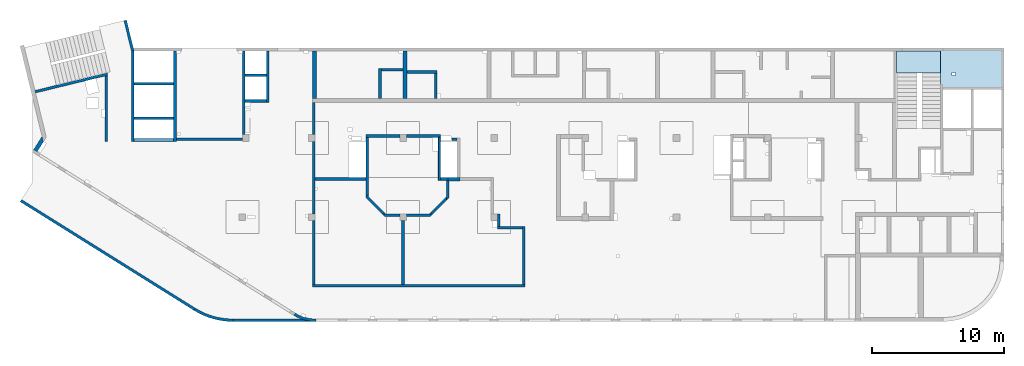
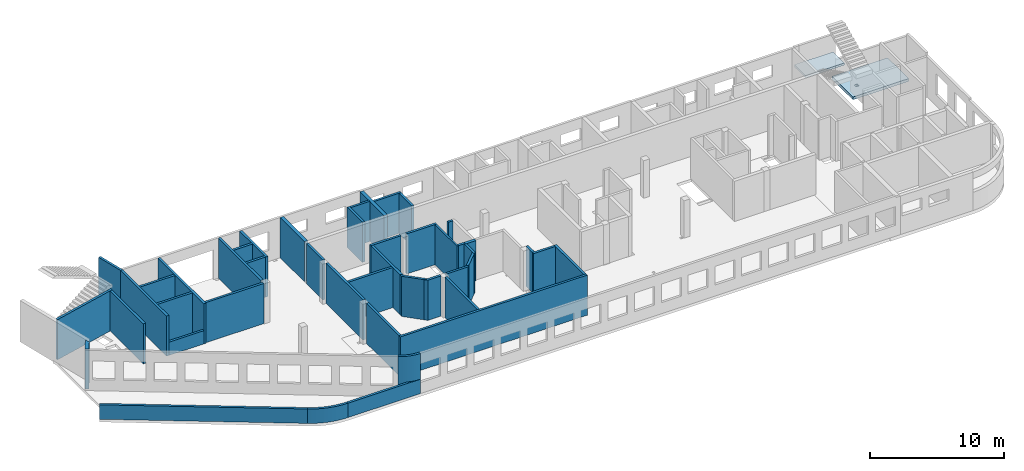
# One storey, part 3 of 10: 45 walls, 2 slabs.
"""IFC4 building model written with IfcOpenShell, lengths in millimetres."""

from ifc_helpers import new_model, entity, si_unit, converted_unit, derived_unit, direction, frame, origin, place, context, subcontext, project, spatial, indexed_curve, outline, extrude, material, type_object, element, save


model = new_model("IFC4")

# Units and contexts
model_context = context("Model", 3, precision=0.01, world=origin(), true_north=direction((6.12303176911189e-17, 1.0)))
plan_context = context("Plan", 3, precision=0.01, world=origin(), true_north=direction((6.12303176911189e-17, 1.0)))
body_context = subcontext(model_context, "Body", "Model", "MODEL_VIEW")
ifc_project = project(units=[si_unit("LENGTHUNIT", "METRE", prefix="MILLI"), si_unit("AREAUNIT", "SQUARE_METRE"), si_unit("VOLUMEUNIT", "CUBIC_METRE"), converted_unit("PLANEANGLEUNIT", "DEGREE", entity("IfcRatioMeasure", 0.0174532925199433), si_unit("PLANEANGLEUNIT", "RADIAN"), dimensions=[0, 0, 0, 0, 0, 0, 0]), si_unit("MASSUNIT", "GRAM", prefix="KILO"), derived_unit("MASSDENSITYUNIT", [(si_unit("MASSUNIT", "GRAM", prefix="KILO"), 1), (si_unit("LENGTHUNIT", "METRE"), -3)]), derived_unit("MOMENTOFINERTIAUNIT", [(si_unit("LENGTHUNIT", "METRE"), 4)]), si_unit("TIMEUNIT", "SECOND"), si_unit("FREQUENCYUNIT", "HERTZ"), si_unit("THERMODYNAMICTEMPERATUREUNIT", "DEGREE_CELSIUS"), derived_unit("THERMALTRANSMITTANCEUNIT", [(si_unit("MASSUNIT", "GRAM", prefix="KILO"), 1), (si_unit("THERMODYNAMICTEMPERATUREUNIT", "KELVIN"), -1), (si_unit("TIMEUNIT", "SECOND"), -3)]), derived_unit("VOLUMETRICFLOWRATEUNIT", [(si_unit("LENGTHUNIT", "METRE"), 3), (si_unit("TIMEUNIT", "SECOND"), -1)]), derived_unit("MASSFLOWRATEUNIT", [(si_unit("MASSUNIT", "GRAM", prefix="KILO"), 1), (si_unit("TIMEUNIT", "SECOND"), -1)]), derived_unit("ROTATIONALFREQUENCYUNIT", [(si_unit("TIMEUNIT", "SECOND"), -1)]), si_unit("ELECTRICCURRENTUNIT", "AMPERE"), si_unit("ELECTRICVOLTAGEUNIT", "VOLT"), si_unit("POWERUNIT", "WATT"), si_unit("FORCEUNIT", "NEWTON", prefix="KILO"), si_unit("ILLUMINANCEUNIT", "LUX"), si_unit("LUMINOUSFLUXUNIT", "LUMEN"), si_unit("LUMINOUSINTENSITYUNIT", "CANDELA"), derived_unit("USERDEFINED", [(si_unit("MASSUNIT", "GRAM", prefix="KILO"), -1), (si_unit("LENGTHUNIT", "METRE"), -2), (si_unit("TIMEUNIT", "SECOND"), 3), (si_unit("LUMINOUSFLUXUNIT", "LUMEN"), 1)]), derived_unit("LINEARVELOCITYUNIT", [(si_unit("LENGTHUNIT", "METRE"), 1), (si_unit("TIMEUNIT", "SECOND"), -1)]), si_unit("PRESSUREUNIT", "PASCAL"), derived_unit("USERDEFINED", [(si_unit("LENGTHUNIT", "METRE"), -2), (si_unit("MASSUNIT", "GRAM", prefix="KILO"), 1), (si_unit("TIMEUNIT", "SECOND"), -2)]), derived_unit("LINEARFORCEUNIT", [(si_unit("MASSUNIT", "GRAM", prefix="KILO"), 1), (si_unit("LENGTHUNIT", "METRE"), 1), (si_unit("TIMEUNIT", "SECOND"), -2), (si_unit("LENGTHUNIT", "METRE"), -1)]), derived_unit("PLANARFORCEUNIT", [(si_unit("MASSUNIT", "GRAM", prefix="KILO"), 1), (si_unit("LENGTHUNIT", "METRE"), 1), (si_unit("TIMEUNIT", "SECOND"), -2), (si_unit("LENGTHUNIT", "METRE"), -2)])], contexts=[model_context, plan_context])

# Site, building, storey
site_placement = place(None, origin())
site = spatial("IfcSite", under=ifc_project, at=site_placement, CompositionType="ELEMENT")
building_placement = place(site_placement, origin())
building = spatial("IfcBuilding", under=site, at=building_placement, CompositionType="ELEMENT")
storey_placement = place(building_placement, frame((0.0, 0.0, 4200.0)))
storey = spatial("IfcBuildingStorey", under=building, at=storey_placement, CompositionType="ELEMENT", Elevation=4200.0)

# Slabs
ifc_material = material()
slab_type_1 = type_object("IfcSlabType", PredefinedType="FLOOR", material=ifc_material)
slab_1_placement = place(storey_placement, origin())
element("IfcSlab", 1, at=slab_1_placement, inside=storey, type_object=slab_type_1, material=ifc_material, PredefinedType="FLOOR", context=body_context, shape_type="SweptSolid", body=[
    extrude(outline(indexed_curve([(-1590.00000000001, -2374.99999999999), (-1390.00000000001, -2374.99999999999), (1539.99999999999, -2375.0), (1540.0, -2175.00000000001), (1540.00000000001, 2225.00000000001), (1540.00000000001, 2425.0), (-1589.99999999999, 2425.00000000001), (-1589.99999999999, 2225.00000000001), (-1590.00000000001, -2374.99999999999)], self_intersect=False), holes=[indexed_curve([(234.999999999561, -1250.00000000008), (484.999999999556, -1250.00000000008), (484.999999999556, -1500.00000000009), (234.999999999561, -1500.00000000009), (234.999999999561, -1250.00000000008)], self_intersect=False)]), frame((71145.0002685547, 18909.999226356, -670.0), z_axis=(0.0, 0.0, 1.0), x_axis=(0.0, -1.0, 0.0)), (0.0, 0.0, 1.0), 250.0),
])
slab_type_2 = type_object("IfcSlabType", PredefinedType="FLOOR", material=ifc_material)
slab_2_placement = place(storey_placement, origin())
element("IfcSlab", 2, at=slab_2_placement, inside=storey, type_object=slab_type_2, material=ifc_material, PredefinedType="FLOOR", context=body_context, shape_type="SweptSolid", body=[
    extrude(outline(indexed_curve([(-835.000000000001, -1670.00000000001), (834.999999999999, -1670.00000000001), (834.999999999999, 1670.00000000002), (-835.000000000001, 1670.00000000002), (-835.000000000001, -1670.00000000001)], self_intersect=False)), frame((67100.0002685547, 19464.999226356, 1920.0), z_axis=(0.0, 0.0, -1.0), x_axis=(0.0, 1.0, 0.0)), (0.0, 0.0, 1.0), 200.0),
])

# Walls
wall_type_1 = type_object("IfcWallType", PredefinedType="STANDARD")
wall_1_placement = place(storey_placement, frame((21465.0002685546, -100.000773643746, 0.0)))
element("IfcWall", 3, at=wall_1_placement, inside=storey, type_object=wall_type_1, material=ifc_material, PredefinedType="NOTDEFINED", context=body_context, shape_type="SweptSolid", body=[
    extrude(outline(indexed_curve([(-1669.73115912917, 370.165232796526), (-1517.43719360754, 282.663604846569), (-1360.57165411762, 203.64974942406), (-1199.60712853313, 133.361711099216), (-1035.02855371873, 72.0112462252115), (-867.331754563609, 19.7831849810763), (-697.021950212787, -23.1651254650805), (-524.612231996435, -56.7042949949421), (-350.622017642682, -80.733280352823), (-175.575486430924, -95.1796895580798), (-5.19776222063229e-11, -100.0), (8.66293703438714e-12, 100.0), (-164.508224209949, 104.513888503701), (-328.521400565226, 118.041970555164), (-491.545970938351, 140.54353665169), (-653.091352173305, 171.950873752934), (-812.671412377304, 212.169469046979), (-969.805933817563, 261.078294363871), (-1124.02205802084, 318.530170380726), (-1274.85570872706, 384.352209522432), (-1421.85298841496, 458.346336225141), (-1564.57154419729, 540.289882996944), (-1669.73115912917, 370.165232796526)], self_intersect=False)), origin(), (0.0, 0.0, 1.0), 3500.0),
])
wall_2_placement = place(storey_placement, frame((-865.407185772802, 8952.80450073423, -150.0), z_axis=(0.0, 0.0, 1.0), x_axis=(0.848052743777572, -0.529911826412028, 0.0)))
element("IfcWall", 4, at=wall_2_placement, inside=storey, type_object=wall_type_1, material=ifc_material, PredefinedType="NOTDEFINED", context=body_context, shape_type="SweptSolid", body=[
    extrude(outline(indexed_curve([(15506.5810864381, 100.0), (-1.03210773261253e-12, 100.0), (-1.94577687295805e-12, -99.9999999999995), (15506.5810864381, -99.9999999999989), (15506.5810864381, 100.0)], self_intersect=False)), origin(), (0.0, 0.0, 1.0), 1310.0),
])
wall_3_placement = place(storey_placement, frame((12284.9914515941, 735.6837964601, -150.0)))
element("IfcWall", 5, at=wall_3_placement, inside=storey, type_object=wall_type_1, material=ifc_material, PredefinedType="NOTDEFINED", context=body_context, shape_type="SweptSolid", body=[
    extrude(outline(indexed_curve([(2915.01250070512, -735.684570137693), (2613.5342675926, -727.260252967498), (2312.99598516675, -702.024663872808), (2014.33436437137, -660.056456568838), (1718.48026701357, -601.486436618048), (1426.35580447471, -526.497153738303), (1138.87146369442, -435.322332836042), (856.923269385443, -328.246145537743), (581.389991323978, -205.602324490218), (313.130405419884, -67.7731231902071), (52.9806171032711, 84.8118754146881), (-52.9806171032429, -84.811875414706), (216.800382689777, -243.0458441733), (494.991419313605, -385.977729561331), (780.725433216402, -513.162044700461), (1073.11185506481, -624.202384384319), (1371.2393814503, -718.752660585296), (1674.17881521919, -796.518181133935), (1980.98596157331, -857.256568208814), (2290.7045709151, -900.778513774291), (2602.36931926479, -926.948369611523), (2915.00881696042, -935.684570103768), (2915.01250070512, -735.684570137693)], self_intersect=False)), origin(), (0.0, 0.0, 1.0), 1310.0),
])
wall_4_placement = place(storey_placement, frame((15200.0021104269, -100.000773643669, -150.0)))
element("IfcWall", 6, at=wall_4_placement, inside=storey, type_object=wall_type_1, material=ifc_material, PredefinedType="NOTDEFINED", context=body_context, shape_type="SweptSolid", body=[
    extrude(outline(indexed_curve([(6264.99815812798, 100.0), (-3.14842759861503e-13, 100.0), (3.14842759861503e-13, -100.0), (6264.99815812798, -100.0), (6264.99815812798, 100.0)], self_intersect=False)), origin(), (0.0, 0.0, 1.0), 1310.0),
])
wall_5_placement = place(storey_placement, frame((220.235605211572, 17202.3781658972, -150.0), z_axis=(0.0, 0.0, 1.0), x_axis=(0.971552058141474, 0.236826092990334, 0.0)))
element("IfcWall", 7, at=wall_5_placement, inside=storey, type_object=wall_type_1, material=ifc_material, PredefinedType="NOTDEFINED", context=body_context, shape_type="SweptSolid", body=[
    extrude(outline(indexed_curve([(5615.84117734387, -100.0), (5664.5932933022, 99.9999999999997), (3.13016279562817e-13, 99.9999999999999), (3.4262592762957e-13, -100.0), (5409.98499256816, -100.000000000001), (5615.84117734387, -100.0)], self_intersect=False)), origin(), (0.0, 0.0, 1.0), 3650.0),
])
wall_6_placement = place(storey_placement, frame((5600.00026855468, 18435.2006849676, -150.0), z_axis=(0.0, 0.0, 1.0), x_axis=(0.0, -1.0, 0.0)))
element("IfcWall", 8, at=wall_6_placement, inside=storey, type_object=wall_type_1, material=ifc_material, PredefinedType="NOTDEFINED", context=body_context, shape_type="SweptSolid", body=[
    extrude(outline(indexed_curve([(4985.20145861122, -100.0), (4985.20145861122, 99.9999999999997), (-1.66881927142981e-13, 100.0), (48.7521159583304, -99.9999999999999), (2585.20145861117, -100.0), (3145.20145861117, -100.0), (4985.20145861122, -100.0)], self_intersect=False)), origin(), (0.0, 0.0, 1.0), 3650.0),
])
wall_7_placement = place(storey_placement, frame((7033.44218130896, 22609.751914045, -150.0), z_axis=(0.0, 0.0, 1.0), x_axis=(0.236826092990336, -0.971552058141474, 0.0)))
element("IfcWall", 9, at=wall_7_placement, inside=storey, type_object=wall_type_1, material=ifc_material, PredefinedType="NOTDEFINED", context=body_context, shape_type="SweptSolid", body=[
    extrude(outline(indexed_curve([(2380.28371765133, -100.0), (2404.30804833155, 99.9999999999996), (2401.76043829435, 99.9999999999994), (2195.90425351863, 99.9999999999995), (9.13669140345519e-13, 99.9999999999997), (-9.13669140345519e-13, -99.9999999999997), (2380.28371765133, -100.0)], self_intersect=False)), origin(), (0.0, 0.0, 1.0), 3650.0),
])
wall_8_placement = place(storey_placement, frame((7600.00026855467, 13449.9992263564, -150.0), z_axis=(0.0, 0.0, 1.0), x_axis=(0.0, 1.0, 0.0)))
element("IfcWall", 10, at=wall_8_placement, inside=storey, type_object=wall_type_1, material=ifc_material, PredefinedType="NOTDEFINED", context=body_context, shape_type="SweptSolid", body=[
    extrude(outline(indexed_curve([(6847.52486422501, -99.9999999999998), (6823.50053354478, 100.0), (2.00396858490402e-12, 100.0), (1.61765673692763e-13, -100.0), (200.0, -99.9999999999997), (1649.99999999998, -99.9999999999995), (1849.99999999998, -100.0), (4249.99999999998, -99.9999999999996), (4449.99999999998, -100.0), (6847.52486422501, -99.9999999999998)], self_intersect=False)), origin(), (0.0, 0.0, 1.0), 3650.0),
])
wall_9_placement = place(storey_placement, frame((10800.0002685547, 20299.9992263564, -150.0), z_axis=(0.0, 0.0, 1.0), x_axis=(0.0, -1.0, 0.0)))
element("IfcWall", 11, at=wall_9_placement, inside=storey, type_object=wall_type_1, material=ifc_material, PredefinedType="NOTDEFINED", context=body_context, shape_type="SweptSolid", body=[
    extrude(outline(indexed_curve([(6849.99999999999, 99.9999999999989), (-1.58082792598304e-13, 99.9999999999989), (1.58082792598304e-13, -99.9999999999989), (6849.99999999999, -99.9999999999989), (6849.99999999999, 99.9999999999989)], self_intersect=False)), origin(), (0.0, 0.0, 1.0), 3650.0),
])
for number, where in (
    (12, (7700.00026855467, 15199.9992263564, -150.0)),
    (13, (7700.00026855468, 17799.9992263564, -150.0)),
):
    element("IfcWall", number, at=place(storey_placement, frame(where)), inside=storey, type_object=wall_type_1, material=ifc_material, PredefinedType="NOTDEFINED", context=body_context, shape_type="SweptSolid", body=[
        extrude(outline(indexed_curve([(3000.0, 99.9999999999989), (-2.88764567812901e-13, 99.9999999999989), (2.88764567812901e-13, -99.9999999999989), (3000.0, -99.9999999999989), (3000.0, 99.9999999999989)], self_intersect=False)), origin(), (0.0, 0.0, 1.0), 3650.0),
    ])
wall_10_placement = place(storey_placement, frame((10900.0002685547, 13599.9992263564, -150.0)))
element("IfcWall", 14, at=wall_10_placement, inside=storey, type_object=wall_type_1, material=ifc_material, PredefinedType="NOTDEFINED", context=body_context, shape_type="SweptSolid", body=[
    extrude(outline(indexed_curve([(4999.99999999999, 99.9999999999989), (-3.03202796203547e-13, 99.9999999999989), (3.03202796203547e-13, -99.9999999999989), (4999.99999999999, -99.9999999999989), (4999.99999999999, 99.9999999999989)], self_intersect=False)), origin(), (0.0, 0.0, 1.0), 3650.0),
])
wall_11_placement = place(storey_placement, frame((16000.0002685547, 13949.9992263563, -150.0), z_axis=(0.0, 0.0, 1.0), x_axis=(0.0, 1.0, 0.0)))
element("IfcWall", 15, at=wall_11_placement, inside=storey, type_object=wall_type_1, material=ifc_material, PredefinedType="NOTDEFINED", context=body_context, shape_type="SweptSolid", body=[
    extrude(outline(indexed_curve([(6350.00000000003, 99.999999999999), (-1.71883671317202e-13, 99.9999999999989), (1.71883671317202e-13, -99.9999999999989), (6350.00000000003, -99.9999999999988), (6350.00000000003, 99.999999999999)], self_intersect=False)), origin(), (0.0, 0.0, 1.0), 3650.0),
])
wall_12_placement = place(storey_placement, frame((17825.0002685547, 20299.9992263564, -150.0), z_axis=(0.0, 0.0, 1.0), x_axis=(0.0, -1.0, 0.0)))
element("IfcWall", 16, at=wall_12_placement, inside=storey, type_object=wall_type_1, material=ifc_material, PredefinedType="NOTDEFINED", context=body_context, shape_type="SweptSolid", body=[
    extrude(outline(indexed_curve([(3900.00000000024, 99.9999999999989), (-1.66594942968972e-13, 99.9999999999989), (1.66594942968972e-13, -99.9999999999989), (3900.00000000024, -99.9999999999989), (3900.00000000024, 99.9999999999989)], self_intersect=False)), origin(), (0.0, 0.0, 1.0), 3650.0),
])
wall_13_placement = place(storey_placement, frame((17725.0002685547, 16499.9992263561, -150.0), z_axis=(0.0, 0.0, 1.0), x_axis=(-1.0, 0.0, 0.0)))
element("IfcWall", 17, at=wall_13_placement, inside=storey, type_object=wall_type_1, material=ifc_material, PredefinedType="NOTDEFINED", context=body_context, shape_type="SweptSolid", body=[
    extrude(outline(indexed_curve([(1624.99999999998, 99.9999999999982), (-3.5601111100221e-13, 99.9999999999989), (3.5601111100221e-13, -99.9999999999989), (1624.99999999998, -99.9999999999996), (1624.99999999998, 99.9999999999982)], self_intersect=False)), origin(), (0.0, 0.0, 1.0), 3650.0),
])
wall_14_placement = place(storey_placement, frame((17725.0002685547, 18449.9992263563, -150.0), z_axis=(0.0, 0.0, 1.0), x_axis=(-1.0, 0.0, 0.0)))
element("IfcWall", 18, at=wall_14_placement, inside=storey, type_object=wall_type_1, material=ifc_material, PredefinedType="NOTDEFINED", context=body_context, shape_type="SweptSolid", body=[
    extrude(outline(indexed_curve([(1624.99999999999, 99.9999999999986), (-3.77156646455302e-13, 99.9999999999989), (3.77156646455302e-13, -99.9999999999989), (1624.99999999999, -99.9999999999993), (1624.99999999999, 99.9999999999986)], self_intersect=False)), origin(), (0.0, 0.0, 1.0), 3650.0),
])
wall_15_placement = place(storey_placement, frame((21320.0002685547, 13949.9992263563, -150.0), z_axis=(0.0, 0.0, 1.0), x_axis=(0.0, 1.0, 0.0)))
element("IfcWall", 19, at=wall_15_placement, inside=storey, type_object=wall_type_1, material=ifc_material, PredefinedType="NOTDEFINED", context=body_context, shape_type="SweptSolid", body=[
    extrude(outline(indexed_curve([(2449.99999999979, 99.9999999999994), (-1.96664178427031e-13, 99.9999999999989), (1.96664178427031e-13, -99.9999999999989), (2449.99999999979, -99.9999999999984), (2449.99999999979, 99.9999999999994)], self_intersect=False)), origin(), (0.0, 0.0, 1.0), 3650.0),
])
wall_16_placement = place(storey_placement, frame((21220.0002685546, 2499.99922635626, -150.0)))
element("IfcWall", 20, at=wall_16_placement, inside=storey, type_object=wall_type_1, material=ifc_material, PredefinedType="NOTDEFINED", context=body_context, shape_type="SweptSolid", body=[
    extrude(outline(indexed_curve([(16075.0, 100.0), (-3.24719987565055e-13, 100.0), (3.24719987565054e-13, -99.9999999999997), (16075.0, -99.9999999999998), (16075.0, 100.0)], self_intersect=False)), origin(), (0.0, 0.0, 1.0), 3650.0),
])
wall_17_placement = place(storey_placement, frame((28070.0002685546, 2599.99922635623, -150.0), z_axis=(0.0, 0.0, 1.0), x_axis=(0.0, 1.0, 0.0)))
element("IfcWall", 21, at=wall_17_placement, inside=storey, type_object=wall_type_1, material=ifc_material, PredefinedType="NOTDEFINED", context=body_context, shape_type="SweptSolid", body=[
    extrude(outline(indexed_curve([(4850.00000000007, 99.9999999999987), (-1.75008828977514e-13, 99.9999999999989), (1.75008828977514e-13, -99.9999999999989), (4850.00000000007, -99.9999999999991), (4850.00000000007, 99.9999999999987)], self_intersect=False)), origin(), (0.0, 0.0, 1.0), 3650.0),
])
wall_18_placement = place(storey_placement, frame((21320.0002685547, 13449.9992263563, -150.0), z_axis=(0.0, 0.0, 1.0), x_axis=(0.0, -1.0, 0.0)))
element("IfcWall", 22, at=wall_18_placement, inside=storey, type_object=wall_type_1, material=ifc_material, PredefinedType="NOTDEFINED", context=body_context, shape_type="SweptSolid", body=[
    extrude(outline(indexed_curve([(5500.0, 99.9999999999989), (-1.57507946079764e-13, 99.9999999999989), (1.57507946079764e-13, -99.9999999999989), (5500.0, -99.9999999999989), (5500.0, 99.9999999999989)], self_intersect=False)), origin(), (0.0, 0.0, 1.0), 3650.0),
])
wall_19_placement = place(storey_placement, frame((21320.0002685546, 7449.99922635633, -150.0), z_axis=(0.0, 0.0, 1.0), x_axis=(0.0, -1.0, 0.0)))
element("IfcWall", 23, at=wall_19_placement, inside=storey, type_object=wall_type_1, material=ifc_material, PredefinedType="NOTDEFINED", context=body_context, shape_type="SweptSolid", body=[
    extrude(outline(indexed_curve([(4850.00000000007, 99.9999999999989), (-1.78617258440967e-13, 99.9999999999989), (1.78617258440967e-13, -99.9999999999989), (4850.00000000007, -99.9999999999989), (4850.00000000007, 99.9999999999989)], self_intersect=False)), origin(), (0.0, 0.0, 1.0), 3650.0),
])
wall_20_placement = place(storey_placement, frame((37195.0002685546, 2599.9992263562, -150.0), z_axis=(0.0, 0.0, 1.0), x_axis=(0.0, 1.0, 0.0)))
element("IfcWall", 24, at=wall_20_placement, inside=storey, type_object=wall_type_1, material=ifc_material, PredefinedType="NOTDEFINED", context=body_context, shape_type="SweptSolid", body=[
    extrude(outline(indexed_curve([(4400.0, 100.0), (-2.32366515949559e-13, 99.9999999999989), (2.32366515949559e-13, -99.9999999999989), (4400.0, -99.9999999999974), (4400.0, 100.0)], self_intersect=False)), origin(), (0.0, 0.0, 1.0), 3650.0),
])
wall_21_placement = place(storey_placement, frame((37095.0002685546, 6899.99922635621, -150.0), z_axis=(0.0, 0.0, 1.0), x_axis=(-1.0, 0.0, 0.0)))
element("IfcWall", 25, at=wall_21_placement, inside=storey, type_object=wall_type_1, material=ifc_material, PredefinedType="NOTDEFINED", context=body_context, shape_type="SweptSolid", body=[
    extrude(outline(indexed_curve([(1875.00000000001, 100.0), (0.0, 100.0), (0.0, -100.0), (1875.00000000001, -100.0), (1875.00000000001, 100.0)], self_intersect=False)), origin(), (0.0, 0.0, 1.0), 3650.0),
])
wall_22_placement = place(storey_placement, frame((35320.0002685546, 6999.99922635621, -150.0), z_axis=(0.0, 0.0, 1.0), x_axis=(0.0, 1.0, 0.0)))
element("IfcWall", 26, at=wall_22_placement, inside=storey, type_object=wall_type_1, material=ifc_material, PredefinedType="NOTDEFINED", context=body_context, shape_type="SweptSolid", body=[
    extrude(outline(indexed_curve([(950.000000000075, 99.9999999999989), (0.0, 99.9999999999989), (0.0, -99.9999999999989), (950.000000000075, -99.9999999999989), (950.000000000075, 99.9999999999989)], self_intersect=False)), origin(), (0.0, 0.0, 1.0), 3650.0),
])
wall_23_placement = place(storey_placement, frame((32170.0002685547, 13599.9992263562, -150.0), z_axis=(0.0, 0.0, 1.0), x_axis=(-1.0, 0.0, 0.0)))
element("IfcWall", 27, at=wall_23_placement, inside=storey, type_object=wall_type_1, material=ifc_material, PredefinedType="NOTDEFINED", context=body_context, shape_type="SweptSolid", body=[
    extrude(outline(indexed_curve([(399.999999999991, 99.9999999999982), (-3.60955709766133e-13, 99.9999999999989), (3.60955709766133e-13, -99.9999999999989), (399.999999999992, -99.9999999999996), (399.999999999991, 99.9999999999982)], self_intersect=False)), origin(), (0.0, 0.0, 1.0), 3650.0),
])
wall_24_placement = place(storey_placement, frame((31460.0002685546, 10489.9992263563, -150.0), z_axis=(0.0, 0.0, 1.0), x_axis=(0.0, -1.0, 0.0)))
element("IfcWall", 28, at=wall_24_placement, inside=storey, type_object=wall_type_1, material=ifc_material, PredefinedType="NOTDEFINED", context=body_context, shape_type="SweptSolid", body=[
    extrude(outline(indexed_curve([(1517.84271247461, -100.000000000004), (1317.84271247462, 99.9999999999959), (65.0000000000382, 99.9999999999968), (65.0000000000372, -2.07407185169571e-12), (-4.33146851719343e-12, 4.33146851719371e-12), (-1.02514551324105e-12, -100.000000000003), (1235.0, -100.000000000004), (1517.84271247461, -100.000000000004)], self_intersect=False)), origin(), (0.0, 0.0, 1.0), 3650.0),
])
wall_25_placement = place(storey_placement, frame((28320.0002685546, 7849.9992263563, -150.0)))
element("IfcWall", 29, at=wall_25_placement, inside=storey, type_object=wall_type_1, material=ifc_material, PredefinedType="NOTDEFINED", context=body_context, shape_type="SweptSolid", body=[
    extrude(outline(indexed_curve([(1817.84271247461, -99.9999999999999), (2017.84271247462, 99.9999999999996), (1735.0, 99.9999999999998), (-3.02005468313109e-13, 100.0), (3.02005468313109e-13, -100.0), (1817.84271247461, -99.9999999999999)], self_intersect=False)), origin(), (0.0, 0.0, 1.0), 3650.0),
])
wall_26_placement = place(storey_placement, frame((27820.0002685546, 7849.9992263563, -150.0), z_axis=(0.0, 0.0, 1.0), x_axis=(-1.0, 0.0, 0.0)))
element("IfcWall", 30, at=wall_26_placement, inside=storey, type_object=wall_type_1, material=ifc_material, PredefinedType="NOTDEFINED", context=body_context, shape_type="SweptSolid", body=[
    extrude(outline(indexed_curve([(1347.84271247462, -99.9999999999998), (1147.84271247462, 100.0), (-4.9488612922406e-13, 100.0), (4.9488612922406e-13, -100.0), (1065.0, -100.0), (1347.84271247462, -99.9999999999998)], self_intersect=False)), origin(), (0.0, 0.0, 1.0), 3650.0),
])
wall_27_placement = place(storey_placement, frame((27820.0002685547, 13849.9992263563, -150.0), z_axis=(0.0, 0.0, 1.0), x_axis=(-1.0, 0.0, 0.0)))
element("IfcWall", 31, at=wall_27_placement, inside=storey, type_object=wall_type_1, material=ifc_material, PredefinedType="NOTDEFINED", context=body_context, shape_type="SweptSolid", body=[
    extrude(outline(indexed_curve([(2570.00000000001, 99.9999999999988), (-3.32131638983616e-13, 99.9999999999989), (3.32131638983616e-13, -99.9999999999989), (2570.00000000001, -99.9999999999991), (2570.00000000001, 99.9999999999988)], self_intersect=False)), origin(), (0.0, 0.0, 1.0), 3650.0),
])
wall_28_placement = place(storey_placement, frame((25350.0002685547, 13749.9992263563, -150.0), z_axis=(0.0, 0.0, 1.0), x_axis=(0.0, -1.0, 0.0)))
element("IfcWall", 32, at=wall_28_placement, inside=storey, type_object=wall_type_1, material=ifc_material, PredefinedType="NOTDEFINED", context=body_context, shape_type="SweptSolid", body=[
    extrude(outline(indexed_curve([(4295.0, -100.000000000003), (4495.00000000001, 99.9999999999989), (0.0, 99.9999999999989), (0.0, -100.000000000003), (3060.00000000004, -100.000000000003), (3260.00000000004, -100.000000000003), (4295.0, -100.000000000003)], self_intersect=False)), origin(), (0.0, 0.0, 1.0), 3650.0),
])
wall_29_placement = place(storey_placement, frame((28320.0002685547, 13849.9992263563, -150.0)))
element("IfcWall", 33, at=wall_29_placement, inside=storey, type_object=wall_type_1, material=ifc_material, PredefinedType="NOTDEFINED", context=body_context, shape_type="SweptSolid", body=[
    extrude(outline(indexed_curve([(2580.0, 99.9999999999998), (-3.67626630400485e-13, 99.9999999999989), (3.67626630400485e-13, -99.9999999999989), (2580.0, -99.9999999999981), (2580.0, 99.9999999999998)], self_intersect=False)), origin(), (0.0, 0.0, 1.0), 3650.0),
])
wall_30_placement = place(storey_placement, frame((31460.0002685546, 10589.9992263563, -150.0), z_axis=(0.0, 0.0, 1.0), x_axis=(-1.0, 0.0, 0.0)))
element("IfcWall", 34, at=wall_30_placement, inside=storey, type_object=wall_type_1, material=ifc_material, PredefinedType="NOTDEFINED", context=body_context, shape_type="SweptSolid", body=[
    extrude(outline(indexed_curve([(559.999999999966, 99.9999999999986), (-1.64731358047439e-12, 99.9999999999989), (1.64731358047439e-12, -99.9999999999989), (559.99999999997, -99.9999999999992), (559.999999999966, 99.9999999999986)], self_intersect=False)), origin(), (0.0, 0.0, 1.0), 3650.0),
])
wall_31_placement = place(storey_placement, frame((26684.289590436, 7879.28854823765, -150.0), z_axis=(0.0, 0.0, 1.0), x_axis=(-0.707106781186546, 0.707106781186549, 0.0)))
element("IfcWall", 35, at=wall_31_placement, inside=storey, type_object=wall_type_1, material=ifc_material, PredefinedType="NOTDEFINED", context=body_context, shape_type="SweptSolid", body=[
    extrude(outline(indexed_curve([(2128.39141137151, -100.000000000002), (1928.39141137151, 99.9999999999984), (200.000000000001, 99.9999999999979), (-1.32820421328006e-12, -100.000000000002), (1845.54869889689, -100.000000000002), (2128.39141137151, -100.000000000002)], self_intersect=False)), origin(), (0.0, 0.0, 1.0), 3650.0),
])
wall_32_placement = place(storey_placement, frame((25250.0002685546, 10589.9992263563, -150.0), z_axis=(0.0, 0.0, 1.0), x_axis=(-1.0, 0.0, 0.0)))
element("IfcWall", 36, at=wall_32_placement, inside=storey, type_object=wall_type_1, material=ifc_material, PredefinedType="NOTDEFINED", context=body_context, shape_type="SweptSolid", body=[
    extrude(outline(indexed_curve([(3830.0, 100.000000000001), (-3.36454200178105e-13, 100.000000000001), (3.36454200178105e-13, -100.000000000001), (3830.0, -100.000000000001), (3830.0, 100.000000000001)], self_intersect=False)), origin(), (0.0, 0.0, 1.0), 3650.0),
])
wall_33_placement = place(storey_placement, frame((30125.7109466733, 7879.28854823764, -150.0), z_axis=(0.0, 0.0, 1.0), x_axis=(0.707106781186548, 0.707106781186547, 0.0)))
element("IfcWall", 37, at=wall_33_placement, inside=storey, type_object=wall_type_1, material=ifc_material, PredefinedType="NOTDEFINED", context=body_context, shape_type="SweptSolid", body=[
    extrude(outline(indexed_curve([(1645.54869889691, -100.000000000003), (1845.5486988969, 99.9999999999981), (6.42952358020921e-13, 99.9999999999982), (200.000000000002, -100.000000000003), (1645.54869889691, -100.000000000003)], self_intersect=False)), origin(), (0.0, 0.0, 1.0), 3650.0),
])
wall_34_placement = place(storey_placement, frame((7700.00026855467, 13549.9992263564, -150.0)))
element("IfcWall", 38, at=wall_34_placement, inside=storey, type_object=wall_type_1, material=ifc_material, PredefinedType="NOTDEFINED", context=body_context, shape_type="SweptSolid", body=[
    extrude(outline(indexed_curve([(3000.0, 99.9999999999989), (-2.88764567812901e-13, 99.9999999999989), (2.88764567812901e-13, -99.9999999999989), (3000.0, -99.9999999999989), (3000.0, 99.9999999999989)], self_intersect=False)), origin(), (0.0, 0.0, 1.0), 1200.0),
])
wall_35_placement = place(storey_placement, frame((26320.0, 16699.9992263561, -150.0), z_axis=(0.0, 0.0, 1.0), x_axis=(0.0, 1.0, 0.0)))
element("IfcWall", 39, at=wall_35_placement, inside=storey, type_object=wall_type_1, material=ifc_material, PredefinedType="NOTDEFINED", context=body_context, shape_type="SweptSolid", body=[
    extrude(outline(indexed_curve([(2280.0007736439, 99.9999999999993), (-2.08243601256231e-13, 99.9999999999989), (2.08243601256231e-13, -99.9999999999989), (2280.0007736439, -99.9999999999985), (2280.0007736439, 99.9999999999993)], self_intersect=False)), origin(), (0.0, 0.0, 1.0), 3650.0),
])
wall_36_placement = place(storey_placement, frame((26420.0, 18880.0, -150.0)))
element("IfcWall", 40, at=wall_36_placement, inside=storey, type_object=wall_type_1, material=ifc_material, PredefinedType="NOTDEFINED", context=body_context, shape_type="SweptSolid", body=[
    extrude(outline(indexed_curve([(1650.00026855482, 99.9999999999989), (-2.62513200739495e-13, 99.9999999999989), (2.62513200739495e-13, -99.9999999999989), (1650.00026855482, -99.9999999999989), (1650.00026855482, 99.9999999999989)], self_intersect=False)), origin(), (0.0, 0.0, 1.0), 3650.0),
])
wall_37_placement = place(storey_placement, frame((28370.0002685547, 18700.0, -150.0)))
element("IfcWall", 41, at=wall_37_placement, inside=storey, type_object=wall_type_1, material=ifc_material, PredefinedType="NOTDEFINED", context=body_context, shape_type="SweptSolid", body=[
    extrude(outline(indexed_curve([(2279.99973144517, 99.9999999999995), (-3.12365558397263e-13, 99.9999999999989), (3.12365558397263e-13, -99.9999999999989), (2279.99973144517, -99.9999999999983), (2279.99973144517, 99.9999999999995)], self_intersect=False)), origin(), (0.0, 0.0, 1.0), 3650.0),
])
wall_38_placement = place(storey_placement, frame((30550.0, 18600.0, -150.0), z_axis=(0.0, 0.0, 1.0), x_axis=(0.0, -1.0, 0.0)))
element("IfcWall", 42, at=wall_38_placement, inside=storey, type_object=wall_type_1, material=ifc_material, PredefinedType="NOTDEFINED", context=body_context, shape_type="SweptSolid", body=[
    extrude(outline(indexed_curve([(1900.0007736439, 99.9999999999989), (-2.27971934394871e-13, 99.9999999999989), (2.27971934394871e-13, -99.9999999999989), (1900.0007736439, -99.9999999999989), (1900.0007736439, 99.9999999999989)], self_intersect=False)), origin(), (0.0, 0.0, 1.0), 3650.0),
])
wall_type_2 = type_object("IfcWallType", PredefinedType="STANDARD")
wall_39_placement = place(storey_placement, frame((233.402151979623, 12729.3714188327, -150.0), z_axis=(0.0, 0.0, 1.0), x_axis=(0.529911826412026, 0.848052743777573, 0.0)))
element("IfcWall", 43, at=wall_39_placement, inside=storey, type_object=wall_type_2, material=ifc_material, PredefinedType="NOTDEFINED", context=body_context, shape_type="SweptSolid", body=[
    extrude(outline(indexed_curve([(896.727593512352, -150.000000000001), (1189.49773437786, 149.999999999999), (2.36031194589259e-12, 149.999999999999), (-7.1063155360207e-13, -150.000000000001), (896.727593512352, -150.000000000001)], self_intersect=False)), origin(), (0.0, 0.0, 1.0), 3650.0),
])
wall_40_placement = place(storey_placement, frame((21370.0002685547, 16699.9992263561, -150.0), z_axis=(0.0, 0.0, 1.0), x_axis=(0.0, 1.0, 0.0)))
element("IfcWall", 44, at=wall_40_placement, inside=storey, type_object=wall_type_2, material=ifc_material, PredefinedType="NOTDEFINED", context=body_context, shape_type="SweptSolid", body=[
    extrude(outline(indexed_curve([(3600.00000000024, 150.0), (-3.27232685993138e-13, 150.000000000001), (3.27232685993138e-13, -150.000000000001), (3600.00000000024, -150.000000000001), (3600.00000000024, 150.0)], self_intersect=False)), origin(), (0.0, 0.0, 1.0), 3650.0),
])
wall_41_placement = place(storey_placement, frame((28220.0002685547, 20299.9992263563, -150.0), z_axis=(0.0, 0.0, 1.0), x_axis=(0.0, -1.0, 0.0)))
element("IfcWall", 45, at=wall_41_placement, inside=storey, type_object=wall_type_2, material=ifc_material, PredefinedType="NOTDEFINED", context=body_context, shape_type="SweptSolid", body=[
    extrude(outline(indexed_curve([(3600.00000000024, 150.000000000001), (-1.806020255871e-13, 150.000000000001), (1.806020255871e-13, -150.000000000001), (3600.00000000024, -150.000000000001), (3600.00000000024, 150.000000000001)], self_intersect=False)), origin(), (0.0, 0.0, 1.0), 3600.0),
])
wall_type_3 = type_object("IfcWallType", PredefinedType="STANDARD")
wall_42_placement = place(storey_placement, frame((32370.0002685547, 10557.4992263563, -150.0), z_axis=(0.0, 0.0, 1.0), x_axis=(-1.0, 0.0, 0.0)))
element("IfcWall", 46, at=wall_42_placement, inside=storey, type_object=wall_type_3, material=ifc_material, PredefinedType="NOTDEFINED", context=body_context, shape_type="SweptSolid", body=[
    extrude(outline(indexed_curve([(910.000000000044, 132.5), (-2.41191922680361e-13, 132.5), (2.41191922680361e-13, -132.5), (910.000000000045, -132.5), (910.000000000044, 132.5)], self_intersect=False)), origin(), (0.0, 0.0, 1.0), 3650.0),
])
wall_type_4 = type_object("IfcWallType", PredefinedType="STANDARD")
wall_43_placement = place(storey_placement, frame((30825.0002685547, 13749.9992263563, -150.0), z_axis=(0.0, 0.0, 1.0), x_axis=(0.0, -1.0, 0.0)))
element("IfcWall", 47, at=wall_43_placement, inside=storey, type_object=wall_type_4, material=ifc_material, PredefinedType="NOTDEFINED", context=body_context, shape_type="SweptSolid", body=[
    extrude(outline(indexed_curve([(3260.00000000004, 75.0000000000003), (0.0, 75.0000000000003), (0.0, -75.0000000000003), (3260.00000000004, -75.0000000000003), (3260.00000000004, 75.0000000000003)], self_intersect=False)), origin(), (0.0, 0.0, 1.0), 3650.0),
])

save(model, "model.ifc")
